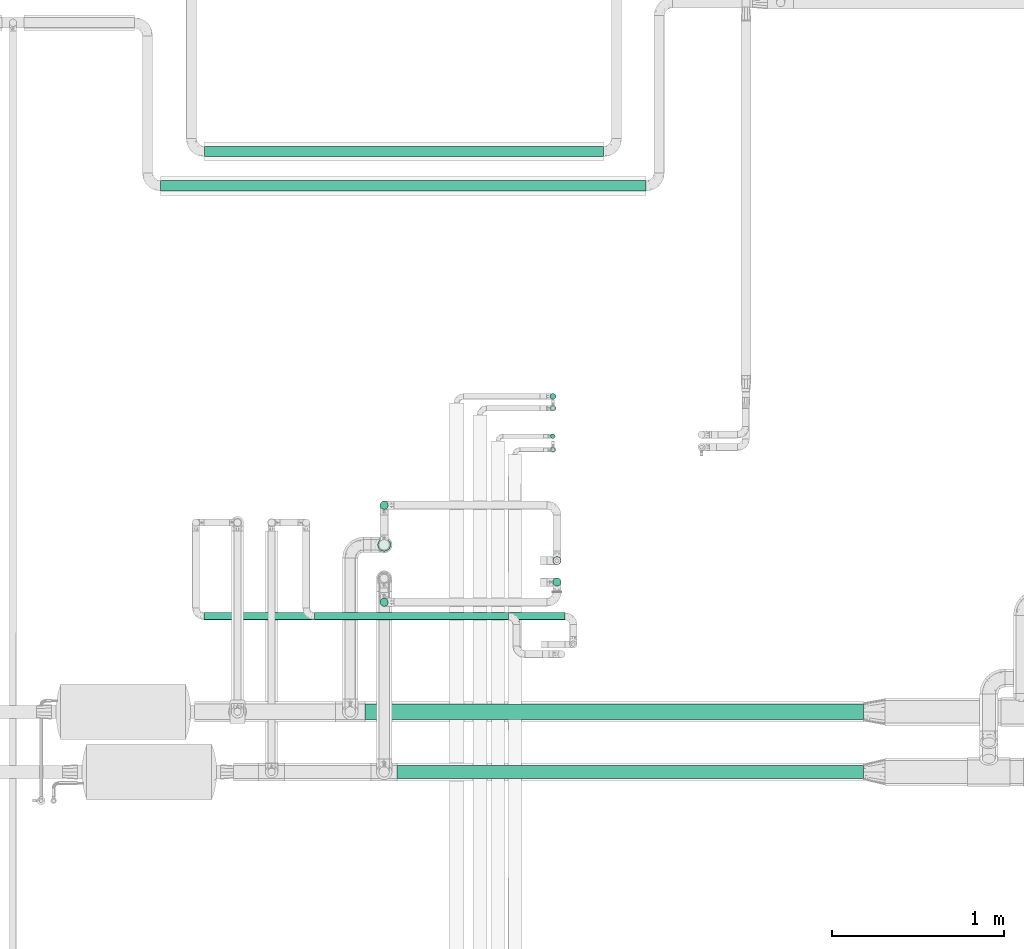
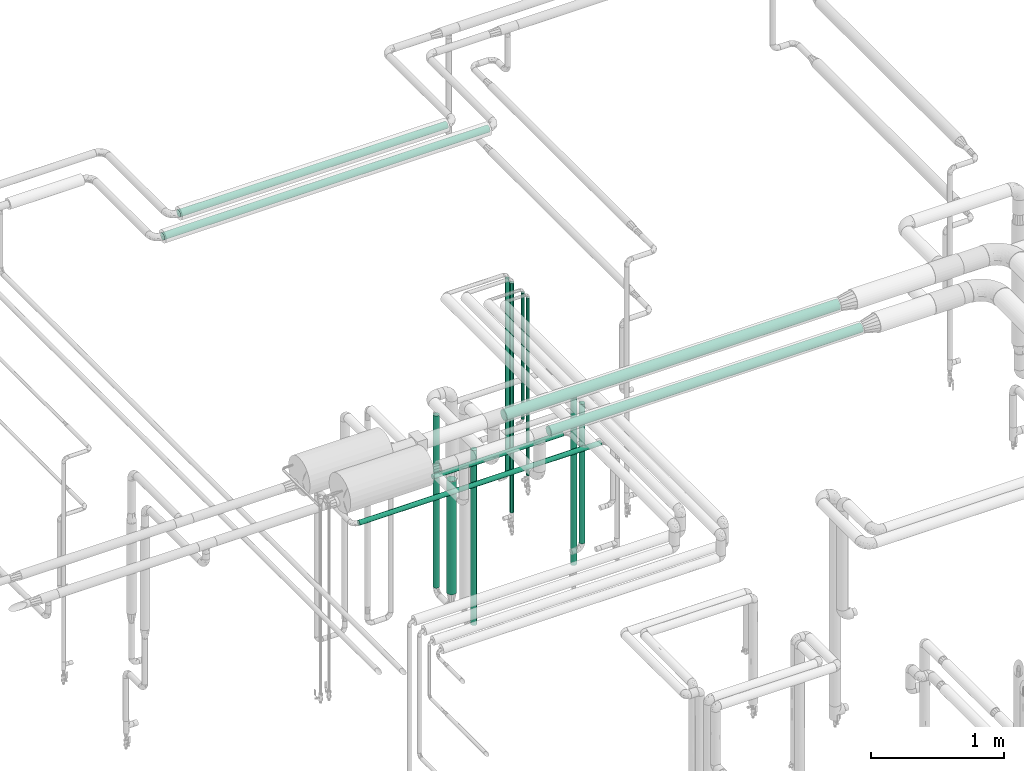
# One storey, part 525 of 827: 15 flow segments.
"""IFC2X3 building model written with IfcOpenShell, lengths in millimetres."""

from ifc_helpers import new_model, entity, si_unit, converted_unit, derived_unit, direction, frame, origin, origin_2d_with_axis, place, context, subcontext, project, spatial, circle, extrude, type_object, element, save


model = new_model("IFC2X3")

# Units and contexts
model_context = context("Model", 3, precision=0.01, world=origin(), true_north=direction((6.12303176911189e-17, 1.0)))
body_context = subcontext(model_context, "Body", "Model", "MODEL_VIEW")
ifc_project = project(units=[si_unit("LENGTHUNIT", "METRE", prefix="MILLI"), si_unit("AREAUNIT", "SQUARE_METRE"), si_unit("VOLUMEUNIT", "CUBIC_METRE"), converted_unit("PLANEANGLEUNIT", "DEGREE", entity("IfcRatioMeasure", 0.0174532925199433), si_unit("PLANEANGLEUNIT", "RADIAN"), dimensions=[0, 0, 0, 0, 0, 0, 0]), si_unit("MASSUNIT", "GRAM", prefix="KILO"), derived_unit("MASSDENSITYUNIT", [(si_unit("MASSUNIT", "GRAM", prefix="KILO"), 1), (si_unit("LENGTHUNIT", "METRE"), -3)]), derived_unit("MOMENTOFINERTIAUNIT", [(si_unit("LENGTHUNIT", "METRE"), 4)]), si_unit("TIMEUNIT", "SECOND"), si_unit("FREQUENCYUNIT", "HERTZ"), si_unit("THERMODYNAMICTEMPERATUREUNIT", "DEGREE_CELSIUS"), derived_unit("THERMALTRANSMITTANCEUNIT", [(si_unit("MASSUNIT", "GRAM", prefix="KILO"), 1), (si_unit("THERMODYNAMICTEMPERATUREUNIT", "KELVIN"), -1), (si_unit("TIMEUNIT", "SECOND"), -3)]), derived_unit("VOLUMETRICFLOWRATEUNIT", [(si_unit("LENGTHUNIT", "METRE"), 3), (si_unit("TIMEUNIT", "SECOND"), -1)]), derived_unit("MASSFLOWRATEUNIT", [(si_unit("MASSUNIT", "GRAM", prefix="KILO"), 1), (si_unit("TIMEUNIT", "SECOND"), -1)]), derived_unit("ROTATIONALFREQUENCYUNIT", [(si_unit("TIMEUNIT", "SECOND"), -1)]), si_unit("ELECTRICCURRENTUNIT", "AMPERE"), si_unit("ELECTRICVOLTAGEUNIT", "VOLT"), si_unit("POWERUNIT", "WATT"), si_unit("FORCEUNIT", "NEWTON", prefix="KILO"), si_unit("ILLUMINANCEUNIT", "LUX"), si_unit("LUMINOUSFLUXUNIT", "LUMEN"), si_unit("LUMINOUSINTENSITYUNIT", "CANDELA"), derived_unit("USERDEFINED", [(si_unit("MASSUNIT", "GRAM", prefix="KILO"), -1), (si_unit("LENGTHUNIT", "METRE"), -2), (si_unit("TIMEUNIT", "SECOND"), 3), (si_unit("LUMINOUSFLUXUNIT", "LUMEN"), 1)]), derived_unit("LINEARVELOCITYUNIT", [(si_unit("LENGTHUNIT", "METRE"), 1), (si_unit("TIMEUNIT", "SECOND"), -1)]), si_unit("PRESSUREUNIT", "PASCAL"), derived_unit("USERDEFINED", [(si_unit("LENGTHUNIT", "METRE"), -2), (si_unit("MASSUNIT", "GRAM", prefix="KILO"), 1), (si_unit("TIMEUNIT", "SECOND"), -2)]), derived_unit("LINEARFORCEUNIT", [(si_unit("MASSUNIT", "GRAM", prefix="KILO"), 1), (si_unit("LENGTHUNIT", "METRE"), 1), (si_unit("TIMEUNIT", "SECOND"), -2), (si_unit("LENGTHUNIT", "METRE"), -1)]), derived_unit("PLANARFORCEUNIT", [(si_unit("MASSUNIT", "GRAM", prefix="KILO"), 1), (si_unit("LENGTHUNIT", "METRE"), 1), (si_unit("TIMEUNIT", "SECOND"), -2), (si_unit("LENGTHUNIT", "METRE"), -2)])], contexts=[model_context])

# Site, building, storey
site_placement = place(None, origin())
site = spatial("IfcSite", under=ifc_project, at=site_placement, CompositionType="ELEMENT")
building_placement = place(site_placement, origin())
building = spatial("IfcBuilding", under=site, at=building_placement, CompositionType="ELEMENT")
storey_placement = place(building_placement, frame((0.0, 0.0, 28200.0)))
storey = spatial("IfcBuildingStorey", under=building, at=storey_placement, Name="08", CompositionType="ELEMENT", Elevation=28200.0)

# Flow segments
pipe_segment_type_1 = type_object("IfcPipeSegmentType", PredefinedType="NOTDEFINED")
flow_segment_1_placement = place(storey_placement, frame((17998.29, 14360.4, 2760.39)))
element("IfcFlowSegment", 1, at=flow_segment_1_placement, inside=storey, type_object=pipe_segment_type_1, context=body_context, shape_type="SweptSolid", body=[
    extrude(circle(Radius=38.0, at=origin_2d_with_axis()), frame((0.0, 39.6, 39.6), z_axis=(1.0, 0.0, 0.0), x_axis=(0.0, 1.0, 0.0)), (0.0, 0.0, 1.0), 2714.60697805768),
])
flow_segment_2_placement = place(storey_placement, frame((17810.74, 14703.7, 2753.9)))
element("IfcFlowSegment", 2, at=flow_segment_2_placement, inside=storey, type_object=pipe_segment_type_1, context=body_context, shape_type="SweptSolid", body=[
    extrude(circle(Radius=44.5, at=origin_2d_with_axis()), frame((0.0, 46.1, 46.1), z_axis=(1.0, 0.0, 0.0), x_axis=(0.0, 1.0, 0.0)), (0.0, 0.0, 1.0), 2902.82745349198),
])
pipe_segment_type_2 = type_object("IfcPipeSegmentType", PredefinedType="NOTDEFINED")
flow_segment_3_placement = place(storey_placement, frame((16620.17, 17781.38, 2968.4)))
element("IfcFlowSegment", 3, at=flow_segment_3_placement, inside=storey, type_object=pipe_segment_type_2, context=body_context, shape_type="SweptSolid", body=[
    extrude(circle(Radius=30.0, at=origin_2d_with_axis()), frame((0.0, 31.6, 31.6), z_axis=(1.0, 0.0, 0.0), x_axis=(0.0, -1.0, 0.0)), (0.0, 0.0, 1.0), 2828.00000000001),
])
flow_segment_4_placement = place(storey_placement, frame((16875.06, 17981.2, 2968.4)))
element("IfcFlowSegment", 4, at=flow_segment_4_placement, inside=storey, type_object=pipe_segment_type_2, context=body_context, shape_type="SweptSolid", body=[
    extrude(circle(Radius=30.0, at=origin_2d_with_axis()), frame((0.0, 31.6, 31.6), z_axis=(1.0, 0.0, 0.0), x_axis=(0.0, -1.0, 0.0)), (0.0, 0.0, 1.0), 2324.875),
])
flow_segment_5_placement = place(storey_placement, frame((17516.2, 15284.04, 1977.25)))
element("IfcFlowSegment", 5, at=flow_segment_5_placement, inside=storey, type_object=pipe_segment_type_2, context=body_context, shape_type="SweptSolid", body=[
    extrude(circle(Radius=21.15, at=origin_2d_with_axis()), frame((0.0, 22.75, 22.75), z_axis=(1.0, 0.0, 0.0), x_axis=(0.0, 1.0, 0.0)), (0.0, 0.0, 1.0), 1129.00000000001),
])
flow_segment_6_placement = place(storey_placement, frame((18890.56, 16261.58, 941.61)))
element("IfcFlowSegment", 6, at=flow_segment_6_placement, inside=storey, type_object=pipe_segment_type_2, context=body_context, shape_type="SweptSolid", body=[
    extrude(circle(Radius=13.4, at=origin_2d_with_axis()), frame((15.0, 15.0, 0.0)), (0.0, 0.0, 1.0), 1629.2855480864),
])
flow_segment_7_placement = place(storey_placement, frame((18890.56, 16339.91, 1411.5)))
element("IfcFlowSegment", 7, at=flow_segment_7_placement, inside=storey, type_object=pipe_segment_type_2, context=body_context, shape_type="SweptSolid", body=[
    extrude(circle(Radius=13.4, at=origin_2d_with_axis()), frame((15.0, 15.0, 0.0)), (0.0, 0.0, 1.0), 1159.39509086874),
])
flow_segment_8_placement = place(storey_placement, frame((18887.21, 16499.57, 457.5)))
element("IfcFlowSegment", 8, at=flow_segment_8_placement, inside=storey, type_object=pipe_segment_type_2, context=body_context, shape_type="SweptSolid", body=[
    extrude(circle(Radius=16.75, at=origin_2d_with_axis()), frame((18.35, 18.35, 0.0)), (0.0, 0.0, 1.0), 2104.5),
])
flow_segment_9_placement = place(storey_placement, frame((18887.21, 16568.25, 776.03)))
element("IfcFlowSegment", 9, at=flow_segment_9_placement, inside=storey, type_object=pipe_segment_type_2, context=body_context, shape_type="SweptSolid", body=[
    extrude(circle(Radius=16.75, at=origin_2d_with_axis()), frame((18.35, 18.35, 0.0)), (0.0, 0.0, 1.0), 1785.97009086874),
])
flow_segment_10_placement = place(storey_placement, frame((16873.63, 15284.04, 1777.25)))
element("IfcFlowSegment", 10, at=flow_segment_10_placement, inside=storey, type_object=pipe_segment_type_2, context=body_context, shape_type="SweptSolid", body=[
    extrude(circle(Radius=21.15, at=origin_2d_with_axis()), frame((0.0, 22.75, 22.75), z_axis=(1.0, 0.0, 0.0), x_axis=(0.0, 1.0, 0.0)), (0.0, 0.0, 1.0), 2102.42263652352),
])
flow_segment_11_placement = place(storey_placement, frame((17896.7, 15927.49, 457.94)))
element("IfcFlowSegment", 11, at=flow_segment_11_placement, inside=storey, type_object=pipe_segment_type_2, context=body_context, shape_type="SweptSolid", body=[
    extrude(circle(Radius=24.0, at=origin_2d_with_axis()), frame((25.6, 25.6, 0.0), z_axis=(0.0, 0.0, 1.0), x_axis=(-1.0, 0.0, 0.0)), (0.0, 0.0, 1.0), 1581.00000000001),
])
flow_segment_12_placement = place(storey_placement, frame((18903.46, 15479.41, 785.03)))
element("IfcFlowSegment", 12, at=flow_segment_12_placement, inside=storey, type_object=pipe_segment_type_2, context=body_context, shape_type="SweptSolid", body=[
    extrude(circle(Radius=24.0, at=origin_2d_with_axis()), frame((25.6, 25.6, 0.0)), (0.0, 0.0, 1.0), 1278.90951544582),
])
flow_segment_13_placement = place(storey_placement, frame((17896.7, 15362.39, 457.94)))
element("IfcFlowSegment", 13, at=flow_segment_13_placement, inside=storey, type_object=pipe_segment_type_2, context=body_context, shape_type="SweptSolid", body=[
    extrude(circle(Radius=24.0, at=origin_2d_with_axis()), frame((25.6, 25.6, 0.0), z_axis=(0.0, 0.0, 1.0), x_axis=(-1.0, 0.0, 0.0)), (0.0, 0.0, 1.0), 1606.0),
])
flow_segment_14_placement = place(storey_placement, frame((18903.46, 15604.41, 509.5)))
element("IfcFlowSegment", 14, at=flow_segment_14_placement, inside=storey, type_object=pipe_segment_type_2, context=body_context, shape_type="SweptSolid", body=[
    extrude(circle(Radius=24.0, at=origin_2d_with_axis()), frame((25.6, 25.6, 0.0)), (0.0, 0.0, 1.0), 1529.43942457708),
])
flow_segment_15_placement = place(storey_placement, frame((17882.95, 15683.1, 546.94)))
element("IfcFlowSegment", 15, at=flow_segment_15_placement, inside=storey, type_object=pipe_segment_type_2, context=body_context, shape_type="SweptSolid", body=[
    extrude(circle(Radius=37.75, at=origin_2d_with_axis()), frame((39.35, 39.35, 0.0)), (0.0, 0.0, 1.0), 1039.3769416054),
])

save(model, "model.ifc")
